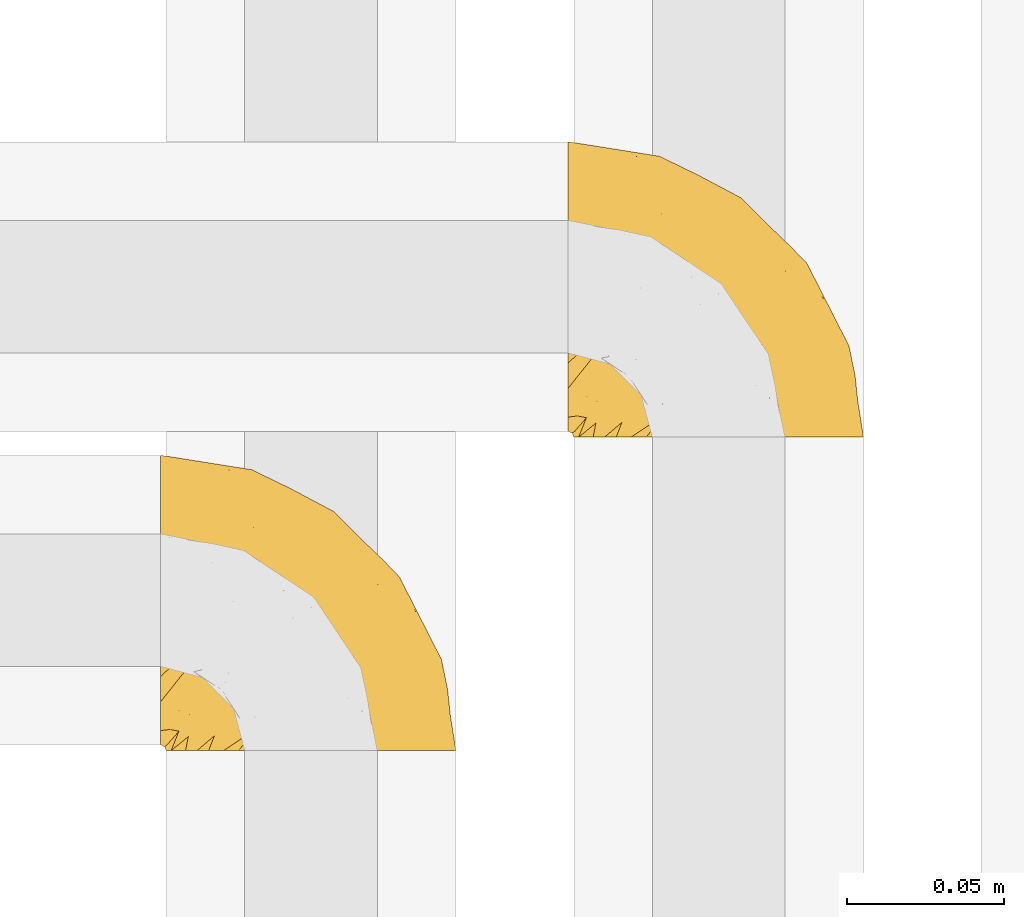
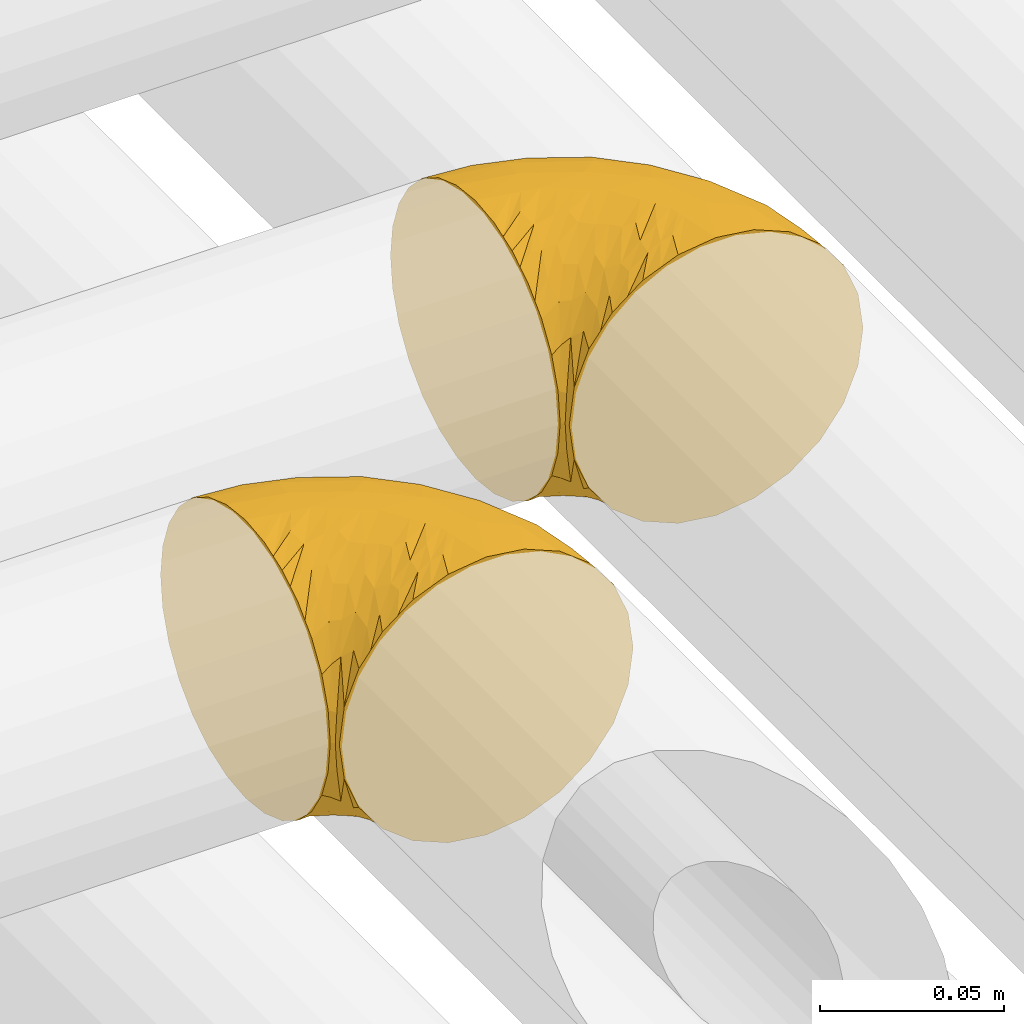
# One storey, part 254 of 827: 2 coverings.
"""IFC2X3 building model written with IfcOpenShell, lengths in millimetres."""

from ifc_helpers import new_model, entity, si_unit, converted_unit, derived_unit, direction, frame, origin, place, context, subcontext, project, spatial, faceted_brep, element, save


model = new_model("IFC2X3")

# Units and contexts
model_context = context("Model", 3, precision=0.01, world=origin(), true_north=direction((6.12303176911189e-17, 1.0)))
body_context = subcontext(model_context, "Body", "Model", "MODEL_VIEW")
ifc_project = project(units=[si_unit("LENGTHUNIT", "METRE", prefix="MILLI"), si_unit("AREAUNIT", "SQUARE_METRE"), si_unit("VOLUMEUNIT", "CUBIC_METRE"), converted_unit("PLANEANGLEUNIT", "DEGREE", entity("IfcRatioMeasure", 0.0174532925199433), si_unit("PLANEANGLEUNIT", "RADIAN"), dimensions=[0, 0, 0, 0, 0, 0, 0]), si_unit("MASSUNIT", "GRAM", prefix="KILO"), derived_unit("MASSDENSITYUNIT", [(si_unit("MASSUNIT", "GRAM", prefix="KILO"), 1), (si_unit("LENGTHUNIT", "METRE"), -3)]), derived_unit("MOMENTOFINERTIAUNIT", [(si_unit("LENGTHUNIT", "METRE"), 4)]), si_unit("TIMEUNIT", "SECOND"), si_unit("FREQUENCYUNIT", "HERTZ"), si_unit("THERMODYNAMICTEMPERATUREUNIT", "DEGREE_CELSIUS"), derived_unit("THERMALTRANSMITTANCEUNIT", [(si_unit("MASSUNIT", "GRAM", prefix="KILO"), 1), (si_unit("THERMODYNAMICTEMPERATUREUNIT", "KELVIN"), -1), (si_unit("TIMEUNIT", "SECOND"), -3)]), derived_unit("VOLUMETRICFLOWRATEUNIT", [(si_unit("LENGTHUNIT", "METRE"), 3), (si_unit("TIMEUNIT", "SECOND"), -1)]), derived_unit("MASSFLOWRATEUNIT", [(si_unit("MASSUNIT", "GRAM", prefix="KILO"), 1), (si_unit("TIMEUNIT", "SECOND"), -1)]), derived_unit("ROTATIONALFREQUENCYUNIT", [(si_unit("TIMEUNIT", "SECOND"), -1)]), si_unit("ELECTRICCURRENTUNIT", "AMPERE"), si_unit("ELECTRICVOLTAGEUNIT", "VOLT"), si_unit("POWERUNIT", "WATT"), si_unit("FORCEUNIT", "NEWTON", prefix="KILO"), si_unit("ILLUMINANCEUNIT", "LUX"), si_unit("LUMINOUSFLUXUNIT", "LUMEN"), si_unit("LUMINOUSINTENSITYUNIT", "CANDELA"), derived_unit("USERDEFINED", [(si_unit("MASSUNIT", "GRAM", prefix="KILO"), -1), (si_unit("LENGTHUNIT", "METRE"), -2), (si_unit("TIMEUNIT", "SECOND"), 3), (si_unit("LUMINOUSFLUXUNIT", "LUMEN"), 1)]), derived_unit("LINEARVELOCITYUNIT", [(si_unit("LENGTHUNIT", "METRE"), 1), (si_unit("TIMEUNIT", "SECOND"), -1)]), si_unit("PRESSUREUNIT", "PASCAL"), derived_unit("USERDEFINED", [(si_unit("LENGTHUNIT", "METRE"), -2), (si_unit("MASSUNIT", "GRAM", prefix="KILO"), 1), (si_unit("TIMEUNIT", "SECOND"), -2)]), derived_unit("LINEARFORCEUNIT", [(si_unit("MASSUNIT", "GRAM", prefix="KILO"), 1), (si_unit("LENGTHUNIT", "METRE"), 1), (si_unit("TIMEUNIT", "SECOND"), -2), (si_unit("LENGTHUNIT", "METRE"), -1)]), derived_unit("PLANARFORCEUNIT", [(si_unit("MASSUNIT", "GRAM", prefix="KILO"), 1), (si_unit("LENGTHUNIT", "METRE"), 1), (si_unit("TIMEUNIT", "SECOND"), -2), (si_unit("LENGTHUNIT", "METRE"), -2)])], contexts=[model_context])

# Site, building, storey
site_placement = place(None, origin())
site = spatial("IfcSite", under=ifc_project, at=site_placement, CompositionType="ELEMENT")
building_placement = place(site_placement, origin())
building = spatial("IfcBuilding", under=site, at=building_placement, CompositionType="ELEMENT")
storey_placement = place(building_placement, frame((0.0, 0.0, 28200.0)))
storey = spatial("IfcBuildingStorey", under=building, at=storey_placement, Name="08", CompositionType="ELEMENT", Elevation=28200.0)

# Coverings
covering_1_placement = place(storey_placement, frame((30866.93, 15691.61, 3152.2)))
element("IfcCovering", 1, at=covering_1_placement, inside=storey, Name=":ADSK_", ObjectType=":ADSK_", PredefinedType="INSULATION", context=body_context, shape_type="Brep", body=[
    faceted_brep([(1.6, 78.41, 83.91), (1.6, 85.72, 76.59), (1.6, 91.22, 67.83), (1.6, 94.64, 58.07), (1.6, 95.8, 47.8), (1.6, 94.64, 37.51), (1.6, 91.22, 27.74), (1.6, 85.71, 18.98), (1.6, 78.39, 11.67), (1.6, 69.63, 6.17), (1.6, 59.87, 2.75), (1.6, 49.6, 1.6), (1.6, 45.45, 2.06), (1.6, 42.38, 2.41), (1.6, 39.31, 2.75), (1.6, 34.43, 4.46), (1.6, 29.54, 6.17), (1.6, 25.16, 8.93), (1.6, 20.78, 11.68), (1.6, 17.13, 15.34), (1.6, 13.47, 19.0), (1.6, 7.97, 27.76), (1.6, 6.26, 32.64), (1.6, 4.55, 37.52), (1.6, 3.4, 47.8), (1.6, 4.55, 58.08), (1.6, 6.26, 62.96), (1.6, 7.97, 67.85), (1.6, 13.48, 76.61), (1.6, 17.14, 80.26), (1.6, 20.8, 83.92), (1.6, 25.18, 86.67), (1.6, 29.56, 89.42), (1.6, 34.44, 91.13), (1.6, 39.32, 92.84), (1.6, 42.39, 93.18), (1.6, 45.45, 93.53), (1.6, 49.6, 94.0), (1.6, 59.88, 92.84), (1.6, 69.65, 89.42), (3.4, 1.6, 47.8), (4.97, 1.6, 35.84), (9.58, 1.6, 24.7), (13.26, 1.6, 19.91), (16.93, 1.6, 15.13), (21.71, 1.6, 11.46), (26.5, 1.6, 7.78), (32.07, 1.6, 5.48), (37.64, 1.6, 3.17), (41.25, 1.6, 2.69), (43.34, 1.6, 2.42), (45.42, 1.6, 2.14), (49.6, 1.6, 1.6), (61.55, 1.6, 3.17), (72.7, 1.6, 7.78), (82.26, 1.6, 15.13), (89.61, 1.6, 24.7), (94.22, 1.6, 35.84), (95.8, 1.6, 47.8), (94.22, 1.6, 59.75), (89.61, 1.6, 70.9), (82.26, 1.6, 80.46), (72.7, 1.6, 87.81), (61.55, 1.6, 92.42), (49.6, 1.6, 94.0), (45.42, 1.6, 93.45), (41.25, 1.6, 92.9), (37.64, 1.6, 92.42), (32.07, 1.6, 90.11), (26.5, 1.6, 87.81), (21.71, 1.6, 84.13), (16.93, 1.6, 80.46), (13.26, 1.6, 75.68), (9.58, 1.6, 70.9), (4.97, 1.6, 59.75), (81.55, 36.81, 71.98), (90.4, 23.28, 63.6), (83.0, 45.8, 59.72), (91.18, 30.7, 47.8), (93.13, 21.2, 55.16), (94.0, 12.96, 47.8), (66.19, 66.19, 63.76), (70.92, 54.51, 72.22), (85.95, 17.98, 74.18), (49.74, 36.69, 92.52), (35.54, 35.54, 94.0), (38.14, 31.64, 94.0), (40.74, 27.75, 94.0), (43.34, 23.86, 94.0), (45.94, 19.96, 94.0), (77.59, 22.8, 82.14), (71.17, 42.67, 80.34), (65.81, 33.21, 87.52), (59.03, 59.45, 79.59), (45.85, 71.5, 78.25), (45.79, 62.66, 85.01), (41.42, 54.5, 90.25), (34.51, 47.57, 93.2), (56.04, 48.81, 87.23), (15.15, 74.98, 85.55), (56.51, 18.7, 93.0), (68.39, 15.75, 89.31), (23.33, 91.17, 61.31), (42.86, 85.28, 56.86), (39.42, 82.58, 68.34), (53.58, 75.78, 65.71), (59.17, 74.98, 56.99), (59.06, 67.27, 72.15), (22.63, 87.38, 70.34), (20.55, 82.04, 78.36), (12.96, 94.0, 47.8), (56.96, 77.8, 47.8), (67.38, 67.38, 47.8), (18.72, 56.2, 93.06), (5.33, 48.85, 94.0), (9.07, 48.11, 94.0), (11.79, 47.57, 94.0), (14.51, 47.03, 94.0), (17.24, 46.48, 94.0), (19.96, 45.94, 94.0), (21.03, 65.78, 89.88), (46.48, 17.24, 94.0), (47.03, 14.51, 94.0), (47.57, 11.79, 94.0), (48.11, 9.07, 94.0), (48.48, 7.2, 94.0), (48.85, 5.33, 94.0), (30.7, 91.18, 47.8), (23.86, 43.34, 94.0), (27.75, 40.74, 94.0), (31.64, 38.14, 94.0), (31.26, 72.73, 83.7), (77.8, 56.96, 47.8), (72.75, 62.23, 55.9), (43.83, 84.49, 47.8), (84.49, 43.83, 47.8), (14.58, 12.05, 81.75), (16.17, 18.95, 86.43), (10.82, 13.02, 79.8), (4.64, 8.34, 69.84), (7.71, 14.63, 79.5), (25.13, 11.09, 88.08), (32.66, 13.66, 91.6), (34.94, 20.08, 92.93), (36.76, 9.61, 92.43), (40.48, 9.48, 93.24), (39.25, 16.1, 93.36), (3.69, 3.42, 57.25), (13.99, 26.63, 89.41), (21.85, 33.72, 92.89), (17.93, 34.77, 92.66), (15.11, 6.75, 79.58), (21.14, 13.31, 86.51), (12.7, 21.11, 86.29), (7.21, 19.94, 83.91), (10.45, 6.04, 73.94), (32.27, 8.67, 90.94), (25.68, 26.11, 91.94), (22.18, 29.3, 91.98), (18.79, 6.32, 82.79), (10.12, 39.92, 93.16), (9.47, 27.05, 88.76), (11.29, 34.4, 91.89), (2.87, 2.87, 47.8), (31.16, 20.92, 92.22), (6.31, 27.43, 88.56), (25.62, 7.54, 87.72), (21.18, 18.45, 88.33), (28.81, 23.88, 92.18), (7.45, 7.77, 71.78), (21.17, 18.43, 7.27), (16.17, 18.93, 9.17), (25.69, 26.08, 3.66), (48.85, 5.33, 1.6), (47.03, 14.51, 1.6), (47.57, 11.79, 1.6), (48.11, 9.07, 1.6), (3.69, 3.42, 38.35), (7.44, 7.76, 23.84), (14.51, 47.03, 1.6), (11.79, 47.57, 1.6), (5.33, 48.85, 1.6), (9.07, 48.11, 1.6), (7.71, 14.62, 16.1), (9.47, 27.03, 6.84), (34.94, 20.08, 2.66), (31.16, 20.92, 3.37), (40.74, 27.75, 1.6), (38.14, 31.64, 1.6), (18.79, 6.33, 12.8), (36.76, 9.61, 3.16), (40.48, 9.48, 2.35), (4.63, 8.33, 25.77), (21.14, 13.3, 9.09), (15.11, 6.74, 16.02), (14.58, 12.04, 13.85), (43.34, 23.86, 1.6), (45.94, 19.96, 1.6), (39.25, 16.1, 2.23), (7.21, 19.93, 11.69), (12.69, 21.1, 9.31), (10.14, 39.92, 2.43), (21.81, 33.68, 2.71), (22.19, 29.28, 3.61), (14.0, 26.62, 6.18), (6.66, 27.87, 6.77), (17.92, 34.75, 2.93), (10.45, 6.04, 21.66), (31.64, 38.14, 1.6), (10.64, 12.79, 16.09), (11.31, 34.41, 3.7), (19.96, 45.94, 1.6), (23.86, 43.34, 1.6), (27.75, 40.74, 1.6), (32.66, 13.66, 3.99), (46.48, 17.24, 1.6), (32.27, 8.67, 4.65), (25.13, 11.09, 7.51), (35.54, 35.54, 1.6), (28.77, 23.83, 3.43), (23.36, 6.03, 9.46), (17.24, 46.48, 1.6), (47.58, 34.52, 2.4), (93.13, 21.2, 40.43), (77.44, 23.82, 13.57), (66.78, 41.32, 11.3), (71.68, 47.62, 18.65), (74.96, 52.66, 27.26), (81.55, 36.81, 23.61), (36.7, 49.75, 3.07), (56.9, 19.07, 2.69), (83.0, 45.8, 35.87), (90.4, 23.28, 31.99), (67.83, 21.35, 6.71), (85.95, 17.98, 21.41), (39.41, 82.57, 27.24), (23.33, 91.17, 34.26), (42.87, 85.27, 38.73), (53.92, 73.89, 26.97), (66.19, 66.19, 31.83), (64.12, 62.43, 23.4), (33.13, 63.53, 6.91), (23.1, 58.45, 3.4), (16.98, 67.16, 5.84), (72.75, 62.22, 39.69), (23.77, 81.54, 17.6), (18.41, 74.8, 10.38), (43.7, 75.83, 20.6), (54.53, 41.45, 5.36), (55.72, 76.72, 35.73), (17.73, 88.2, 24.84), (38.98, 71.6, 13.87), (50.28, 56.23, 9.06), (59.02, 59.44, 15.99)], [[[0, 1, 2, 3, 4, 5, 6, 7, 8, 9, 10, 11, 12, 13, 14, 15, 16, 17, 18, 19, 20, 21, 22, 23, 24, 25, 26, 27, 28, 29, 30, 31, 32, 33, 34, 35, 36, 37, 38, 39]], [[40, 41, 42, 43, 44, 45, 46, 47, 48, 49, 50, 51, 52, 53, 54, 55, 56, 57, 58, 59, 60, 61, 62, 63, 64, 65, 66, 67, 68, 69, 70, 71, 72, 73, 74]], [[75, 76, 77]], [[78, 79, 80]], [[77, 81, 82]], [[76, 75, 83]], [[84, 85, 86, 87, 88, 89]], [[90, 91, 92]], [[76, 60, 59]], [[93, 94, 95]], [[90, 62, 61]], [[83, 61, 60]], [[96, 97, 84]], [[98, 93, 95]], [[0, 39, 99]], [[100, 84, 89]], [[62, 101, 63]], [[2, 102, 3]], [[92, 84, 100]], [[103, 102, 104]], [[103, 105, 106]], [[93, 107, 94]], [[1, 108, 2]], [[92, 101, 90]], [[108, 1, 109]], [[102, 110, 3]], [[93, 82, 107]], [[102, 108, 104]], [[111, 106, 112]], [[109, 0, 99]], [[113, 37, 114, 115, 116, 117, 118, 119]], [[120, 38, 113]], [[100, 89, 121, 122, 123, 124, 125, 126, 64]], [[127, 102, 103]], [[97, 119, 128, 129, 130, 85]], [[99, 120, 131]], [[132, 133, 77]], [[59, 80, 79]], [[1, 0, 109]], [[98, 84, 92]], [[94, 109, 131]], [[120, 39, 38]], [[93, 91, 82]], [[104, 94, 105]], [[97, 113, 119]], [[95, 120, 96]], [[83, 90, 61]], [[91, 93, 98]], [[64, 63, 100]], [[100, 63, 101]], [[77, 76, 79]], [[133, 106, 81]], [[84, 97, 85]], [[113, 96, 120]], [[113, 97, 96]], [[37, 113, 38]], [[110, 102, 127]], [[110, 4, 3]], [[103, 111, 134, 127]], [[90, 75, 91]], [[82, 81, 107]], [[91, 75, 82]], [[77, 82, 75]], [[76, 83, 60]], [[90, 83, 75]], [[105, 107, 81]], [[94, 131, 95]], [[105, 94, 107]], [[109, 94, 104]], [[120, 95, 131]], [[98, 95, 96]], [[84, 98, 96]], [[98, 92, 91]], [[106, 105, 81]], [[103, 104, 105]], [[133, 132, 112]], [[103, 106, 111]], [[77, 78, 135, 132]], [[106, 133, 112]], [[77, 133, 81]], [[120, 99, 39]], [[109, 99, 131]], [[59, 58, 80]], [[59, 79, 76]], [[90, 101, 62]], [[100, 101, 92]], [[2, 108, 102]], [[109, 104, 108]], [[78, 77, 79]], [[136, 137, 138]], [[27, 139, 140]], [[141, 142, 143]], [[144, 145, 121]], [[146, 89, 88]], [[147, 139, 25]], [[148, 149, 150]], [[136, 151, 152]], [[147, 40, 74]], [[24, 147, 25]], [[140, 153, 154]], [[33, 116, 34]], [[73, 151, 155]], [[114, 37, 36, 35, 34, 116, 115]], [[146, 156, 144]], [[157, 85, 130]], [[158, 149, 148]], [[151, 159, 152]], [[117, 33, 160]], [[29, 154, 161]], [[155, 74, 73]], [[162, 128, 119]], [[65, 64, 126, 125, 124, 123, 122, 67, 66]], [[163, 147, 24]], [[27, 140, 28]], [[149, 129, 150]], [[139, 27, 26, 25]], [[68, 144, 69]], [[129, 128, 150]], [[164, 87, 86]], [[130, 129, 149]], [[122, 145, 67]], [[154, 153, 148]], [[162, 119, 160]], [[165, 30, 161]], [[150, 161, 148]], [[128, 162, 150]], [[30, 165, 31]], [[145, 144, 68]], [[89, 146, 144]], [[87, 164, 143]], [[166, 156, 142]], [[88, 87, 143]], [[162, 161, 150]], [[161, 30, 29]], [[154, 29, 28]], [[140, 154, 28]], [[161, 154, 148]], [[140, 137, 153]], [[158, 148, 153]], [[157, 130, 158]], [[153, 137, 158]], [[158, 137, 157]], [[167, 137, 136]], [[168, 85, 157]], [[152, 168, 167]], [[167, 168, 157]], [[164, 152, 141]], [[151, 73, 72]], [[159, 72, 71]], [[88, 142, 146]], [[144, 156, 69]], [[146, 142, 156]], [[70, 166, 71]], [[142, 141, 166]], [[70, 69, 156]], [[141, 159, 71]], [[167, 136, 152]], [[138, 137, 140]], [[155, 136, 169]], [[136, 155, 151]], [[74, 155, 169]], [[152, 159, 141]], [[151, 72, 159]], [[168, 152, 164]], [[137, 167, 157]], [[164, 86, 168]], [[85, 168, 86]], [[116, 33, 117]], [[130, 149, 158]], [[67, 145, 68]], [[121, 89, 144]], [[145, 122, 121]], [[40, 147, 163]], [[169, 147, 74]], [[160, 33, 32]], [[162, 160, 32]], [[160, 119, 118, 117]], [[139, 147, 169]], [[139, 169, 138]], [[162, 32, 31]], [[141, 143, 164]], [[88, 143, 142]], [[71, 166, 141]], [[156, 166, 70]], [[139, 138, 140]], [[169, 136, 138]], [[161, 162, 165]], [[162, 31, 165]], [[170, 171, 172]], [[173, 52, 51, 50, 49, 48, 174, 175, 176]], [[177, 178, 41]], [[179, 15, 180]], [[12, 11, 181, 182, 180, 14, 13]], [[183, 21, 20]], [[19, 18, 184]], [[185, 186, 187]], [[186, 188, 187]], [[43, 189, 44]], [[190, 191, 47]], [[23, 22, 21, 192]], [[193, 194, 195]], [[40, 163, 177]], [[196, 197, 198]], [[24, 23, 177]], [[199, 200, 183]], [[201, 15, 179]], [[178, 177, 192]], [[47, 46, 190]], [[202, 203, 204]], [[203, 172, 171]], [[205, 206, 184]], [[207, 41, 178]], [[16, 15, 201]], [[14, 180, 15]], [[204, 203, 200]], [[208, 203, 202]], [[163, 24, 177]], [[48, 47, 191]], [[198, 197, 190]], [[199, 184, 204]], [[171, 195, 209]], [[210, 211, 212]], [[206, 212, 213]], [[205, 17, 210]], [[184, 206, 204]], [[210, 212, 206]], [[185, 196, 214]], [[190, 215, 191]], [[216, 45, 214]], [[186, 217, 193]], [[190, 216, 198]], [[19, 184, 199]], [[196, 185, 187]], [[19, 199, 20]], [[200, 199, 204]], [[183, 20, 199]], [[206, 202, 204]], [[171, 183, 200]], [[203, 208, 172]], [[172, 208, 218]], [[171, 200, 203]], [[218, 188, 219]], [[195, 170, 193]], [[217, 186, 185]], [[193, 219, 186]], [[193, 170, 219]], [[207, 194, 42]], [[217, 220, 189]], [[216, 190, 46]], [[214, 196, 198]], [[44, 220, 45]], [[214, 198, 216]], [[216, 46, 45]], [[214, 45, 220]], [[42, 194, 43]], [[189, 193, 217]], [[207, 195, 194]], [[209, 195, 178]], [[41, 207, 42]], [[195, 207, 178]], [[43, 194, 189]], [[193, 189, 194]], [[171, 170, 195]], [[170, 172, 219]], [[218, 219, 172]], [[188, 186, 219]], [[206, 213, 202]], [[208, 202, 213]], [[201, 210, 16]], [[215, 190, 197]], [[215, 174, 191]], [[174, 48, 191]], [[201, 179, 221, 211]], [[210, 201, 211]], [[23, 192, 177]], [[40, 177, 41]], [[192, 183, 209]], [[21, 183, 192]], [[205, 18, 17]], [[17, 16, 210]], [[217, 185, 214]], [[189, 220, 44]], [[214, 220, 217]], [[192, 209, 178]], [[171, 209, 183]], [[206, 205, 210]], [[18, 205, 184]], [[222, 197, 196, 187, 188, 218]], [[57, 223, 80]], [[224, 225, 226]], [[226, 227, 228]], [[229, 218, 208, 213, 212, 211]], [[230, 52, 173, 176, 175, 174, 215, 197]], [[231, 232, 228]], [[231, 78, 223]], [[223, 57, 232]], [[224, 233, 225]], [[233, 54, 53]], [[234, 232, 56]], [[56, 55, 234]], [[234, 224, 228]], [[235, 236, 237]], [[224, 55, 54]], [[238, 239, 240]], [[52, 230, 53]], [[241, 242, 243]], [[227, 244, 231]], [[11, 10, 242]], [[236, 6, 5]], [[7, 245, 8]], [[8, 246, 9]], [[238, 247, 235]], [[222, 229, 248]], [[242, 211, 221, 179, 180, 182, 181, 11]], [[233, 53, 230]], [[111, 112, 249]], [[250, 6, 236]], [[246, 251, 241]], [[6, 250, 7]], [[127, 236, 110]], [[248, 229, 252]], [[246, 8, 245]], [[235, 245, 250]], [[236, 5, 110]], [[235, 249, 238]], [[237, 236, 127]], [[243, 9, 246]], [[252, 229, 241]], [[56, 232, 57]], [[222, 230, 197]], [[225, 248, 252]], [[248, 233, 230]], [[54, 233, 224]], [[231, 228, 227]], [[244, 132, 231]], [[248, 225, 233]], [[226, 225, 253]], [[235, 250, 236]], [[245, 7, 250]], [[251, 246, 245]], [[243, 246, 241]], [[247, 245, 235]], [[252, 251, 253]], [[229, 222, 218]], [[230, 222, 248]], [[5, 4, 110]], [[237, 127, 134, 111]], [[238, 249, 239]], [[224, 234, 55]], [[232, 234, 228]], [[242, 241, 229]], [[10, 9, 243]], [[211, 242, 229]], [[10, 243, 242]], [[80, 223, 78]], [[80, 58, 57]], [[231, 223, 232]], [[227, 240, 239]], [[224, 226, 228]], [[240, 226, 253]], [[227, 239, 244]], [[226, 240, 227]], [[251, 247, 253]], [[240, 253, 247]], [[249, 235, 237]], [[237, 111, 249]], [[112, 132, 244]], [[112, 244, 249]], [[78, 231, 132, 135]], [[249, 244, 239]], [[247, 238, 240]], [[245, 247, 251]], [[251, 252, 241]], [[225, 252, 253]]]),
])
covering_2_placement = place(storey_placement, frame((30996.93, 15791.61, 3152.2)))
element("IfcCovering", 2, at=covering_2_placement, inside=storey, Name=":ADSK_", ObjectType=":ADSK_", PredefinedType="INSULATION", context=body_context, shape_type="Brep", body=[
    faceted_brep([(1.6, 78.41, 83.91), (1.6, 85.72, 76.59), (1.6, 91.22, 67.83), (1.6, 94.64, 58.07), (1.6, 95.8, 47.8), (1.6, 94.64, 37.51), (1.6, 91.22, 27.74), (1.6, 85.71, 18.98), (1.6, 78.39, 11.67), (1.6, 69.63, 6.17), (1.6, 59.87, 2.75), (1.6, 49.6, 1.6), (1.6, 45.45, 2.06), (1.6, 42.38, 2.41), (1.6, 39.31, 2.75), (1.6, 34.43, 4.46), (1.6, 29.54, 6.17), (1.6, 25.16, 8.93), (1.6, 20.78, 11.68), (1.6, 17.13, 15.34), (1.6, 13.47, 19.0), (1.6, 7.97, 27.76), (1.6, 6.26, 32.64), (1.6, 4.55, 37.52), (1.6, 3.4, 47.8), (1.6, 4.55, 58.08), (1.6, 6.26, 62.96), (1.6, 7.97, 67.85), (1.6, 13.48, 76.61), (1.6, 17.14, 80.26), (1.6, 20.8, 83.92), (1.6, 25.18, 86.67), (1.6, 29.56, 89.42), (1.6, 34.44, 91.13), (1.6, 39.32, 92.84), (1.6, 42.39, 93.18), (1.6, 45.45, 93.53), (1.6, 49.6, 94.0), (1.6, 59.88, 92.84), (1.6, 69.65, 89.42), (3.4, 1.6, 47.8), (4.97, 1.6, 35.84), (9.58, 1.6, 24.7), (13.26, 1.6, 19.91), (16.93, 1.6, 15.13), (21.71, 1.6, 11.46), (26.5, 1.6, 7.78), (32.07, 1.6, 5.48), (37.64, 1.6, 3.17), (41.25, 1.6, 2.69), (43.34, 1.6, 2.42), (45.42, 1.6, 2.14), (49.6, 1.6, 1.6), (61.55, 1.6, 3.17), (72.7, 1.6, 7.78), (82.26, 1.6, 15.13), (89.61, 1.6, 24.7), (94.22, 1.6, 35.84), (95.8, 1.6, 47.8), (94.22, 1.6, 59.75), (89.61, 1.6, 70.9), (82.26, 1.6, 80.46), (72.7, 1.6, 87.81), (61.55, 1.6, 92.42), (49.6, 1.6, 94.0), (45.42, 1.6, 93.45), (41.25, 1.6, 92.9), (37.64, 1.6, 92.42), (32.07, 1.6, 90.11), (26.5, 1.6, 87.81), (21.71, 1.6, 84.13), (16.93, 1.6, 80.46), (13.26, 1.6, 75.68), (9.58, 1.6, 70.9), (4.97, 1.6, 59.75), (81.55, 36.81, 71.98), (90.4, 23.28, 63.6), (83.0, 45.8, 59.72), (91.18, 30.7, 47.8), (93.13, 21.2, 55.16), (94.0, 12.96, 47.8), (66.19, 66.19, 63.76), (70.92, 54.51, 72.22), (85.95, 17.98, 74.18), (49.74, 36.69, 92.52), (35.54, 35.54, 94.0), (38.14, 31.64, 94.0), (40.74, 27.75, 94.0), (43.34, 23.86, 94.0), (45.94, 19.96, 94.0), (77.59, 22.8, 82.14), (71.17, 42.67, 80.34), (65.81, 33.21, 87.52), (59.03, 59.45, 79.59), (45.85, 71.5, 78.25), (45.79, 62.66, 85.01), (41.42, 54.5, 90.25), (34.51, 47.57, 93.2), (56.04, 48.81, 87.23), (15.15, 74.98, 85.55), (56.51, 18.7, 93.0), (68.39, 15.75, 89.31), (23.33, 91.17, 61.31), (42.86, 85.28, 56.86), (39.42, 82.58, 68.34), (53.58, 75.78, 65.71), (59.17, 74.98, 56.99), (59.06, 67.27, 72.15), (22.63, 87.38, 70.34), (20.55, 82.04, 78.36), (12.96, 94.0, 47.8), (56.96, 77.8, 47.8), (67.38, 67.38, 47.8), (18.72, 56.2, 93.06), (5.33, 48.85, 94.0), (9.07, 48.11, 94.0), (11.79, 47.57, 94.0), (14.51, 47.03, 94.0), (17.24, 46.48, 94.0), (19.96, 45.94, 94.0), (21.03, 65.78, 89.88), (46.48, 17.24, 94.0), (47.03, 14.51, 94.0), (47.57, 11.79, 94.0), (48.11, 9.07, 94.0), (48.48, 7.2, 94.0), (48.85, 5.33, 94.0), (30.7, 91.18, 47.8), (23.86, 43.34, 94.0), (27.75, 40.74, 94.0), (31.64, 38.14, 94.0), (31.26, 72.73, 83.7), (77.8, 56.96, 47.8), (72.75, 62.23, 55.9), (43.83, 84.49, 47.8), (84.49, 43.83, 47.8), (14.58, 12.05, 81.75), (16.17, 18.95, 86.43), (10.82, 13.02, 79.8), (4.64, 8.34, 69.84), (7.71, 14.63, 79.5), (25.13, 11.09, 88.08), (32.66, 13.66, 91.6), (34.94, 20.08, 92.93), (36.76, 9.61, 92.43), (40.48, 9.48, 93.24), (39.25, 16.1, 93.36), (3.69, 3.42, 57.25), (13.99, 26.63, 89.41), (21.85, 33.72, 92.89), (17.93, 34.77, 92.66), (15.11, 6.75, 79.58), (21.14, 13.31, 86.51), (7.21, 19.94, 83.91), (9.47, 27.05, 88.76), (10.45, 6.04, 73.94), (32.27, 8.67, 90.94), (25.68, 26.11, 91.94), (22.18, 29.3, 91.98), (18.79, 6.32, 82.79), (10.12, 39.92, 93.16), (11.29, 34.4, 91.89), (2.87, 2.87, 47.8), (31.16, 20.92, 92.22), (12.7, 21.11, 86.29), (6.31, 27.43, 88.56), (25.62, 7.54, 87.72), (21.18, 18.45, 88.33), (28.81, 23.88, 92.18), (7.45, 7.77, 71.78), (21.14, 13.3, 9.09), (25.13, 11.09, 7.51), (18.79, 6.33, 12.8), (48.11, 9.07, 1.6), (48.85, 5.33, 1.6), (47.03, 14.51, 1.6), (47.57, 11.79, 1.6), (3.69, 3.42, 38.35), (7.44, 7.76, 23.84), (14.51, 47.03, 1.6), (11.79, 47.57, 1.6), (5.33, 48.85, 1.6), (9.07, 48.11, 1.6), (7.71, 14.62, 16.1), (9.47, 27.03, 6.84), (34.94, 20.08, 2.66), (31.16, 20.92, 3.37), (40.74, 27.75, 1.6), (38.14, 31.64, 1.6), (36.76, 9.61, 3.16), (40.48, 9.48, 2.35), (4.63, 8.33, 25.77), (15.11, 6.74, 16.02), (14.58, 12.04, 13.85), (43.34, 23.86, 1.6), (45.94, 19.96, 1.6), (39.25, 16.1, 2.23), (7.21, 19.93, 11.69), (12.69, 21.1, 9.31), (10.14, 39.92, 2.43), (21.81, 33.68, 2.71), (22.19, 29.28, 3.61), (14.0, 26.62, 6.18), (25.69, 26.08, 3.66), (16.17, 18.93, 9.17), (6.66, 27.87, 6.77), (17.92, 34.75, 2.93), (10.45, 6.04, 21.66), (31.64, 38.14, 1.6), (10.64, 12.79, 16.09), (11.31, 34.41, 3.7), (19.96, 45.94, 1.6), (23.86, 43.34, 1.6), (27.75, 40.74, 1.6), (32.66, 13.66, 3.99), (46.48, 17.24, 1.6), (32.27, 8.67, 4.65), (35.54, 35.54, 1.6), (28.77, 23.83, 3.43), (21.17, 18.43, 7.27), (23.36, 6.03, 9.46), (17.24, 46.48, 1.6), (47.58, 34.52, 2.4), (93.13, 21.2, 40.43), (77.44, 23.82, 13.57), (66.78, 41.32, 11.3), (71.68, 47.62, 18.65), (74.96, 52.66, 27.26), (81.55, 36.81, 23.61), (36.7, 49.75, 3.07), (56.9, 19.07, 2.69), (83.0, 45.8, 35.87), (90.4, 23.28, 31.99), (67.83, 21.35, 6.71), (85.95, 17.98, 21.41), (39.41, 82.57, 27.24), (23.33, 91.17, 34.26), (42.87, 85.27, 38.73), (53.92, 73.89, 26.97), (66.19, 66.19, 31.83), (64.12, 62.43, 23.4), (33.13, 63.53, 6.91), (23.1, 58.45, 3.4), (16.98, 67.16, 5.84), (55.72, 76.72, 35.73), (72.75, 62.22, 39.69), (23.77, 81.54, 17.6), (18.41, 74.8, 10.38), (43.7, 75.83, 20.6), (54.53, 41.45, 5.36), (17.73, 88.2, 24.84), (38.98, 71.6, 13.87), (50.28, 56.23, 9.06), (59.02, 59.44, 15.99)], [[[0, 1, 2, 3, 4, 5, 6, 7, 8, 9, 10, 11, 12, 13, 14, 15, 16, 17, 18, 19, 20, 21, 22, 23, 24, 25, 26, 27, 28, 29, 30, 31, 32, 33, 34, 35, 36, 37, 38, 39]], [[40, 41, 42, 43, 44, 45, 46, 47, 48, 49, 50, 51, 52, 53, 54, 55, 56, 57, 58, 59, 60, 61, 62, 63, 64, 65, 66, 67, 68, 69, 70, 71, 72, 73, 74]], [[75, 76, 77]], [[78, 79, 80]], [[77, 81, 82]], [[76, 75, 83]], [[84, 85, 86, 87, 88, 89]], [[90, 91, 92]], [[76, 60, 59]], [[93, 94, 95]], [[90, 62, 61]], [[83, 61, 60]], [[96, 97, 84]], [[98, 93, 95]], [[0, 39, 99]], [[100, 84, 89]], [[62, 101, 63]], [[2, 102, 3]], [[92, 84, 100]], [[103, 102, 104]], [[103, 105, 106]], [[93, 107, 94]], [[1, 108, 2]], [[92, 101, 90]], [[108, 1, 109]], [[102, 110, 3]], [[93, 82, 107]], [[102, 108, 104]], [[111, 106, 112]], [[109, 0, 99]], [[113, 37, 114, 115, 116, 117, 118, 119]], [[120, 38, 113]], [[100, 89, 121, 122, 123, 124, 125, 126, 64]], [[127, 102, 103]], [[97, 119, 128, 129, 130, 85]], [[99, 120, 131]], [[132, 133, 77]], [[59, 80, 79]], [[1, 0, 109]], [[98, 84, 92]], [[94, 109, 131]], [[120, 39, 38]], [[93, 91, 82]], [[104, 94, 105]], [[97, 113, 119]], [[95, 120, 96]], [[83, 90, 61]], [[91, 93, 98]], [[64, 63, 100]], [[100, 63, 101]], [[77, 76, 79]], [[133, 106, 81]], [[84, 97, 85]], [[113, 96, 120]], [[113, 97, 96]], [[37, 113, 38]], [[110, 102, 127]], [[110, 4, 3]], [[103, 111, 134, 127]], [[90, 75, 91]], [[82, 81, 107]], [[91, 75, 82]], [[77, 82, 75]], [[76, 83, 60]], [[90, 83, 75]], [[105, 107, 81]], [[94, 131, 95]], [[105, 94, 107]], [[109, 94, 104]], [[120, 95, 131]], [[98, 95, 96]], [[84, 98, 96]], [[98, 92, 91]], [[106, 105, 81]], [[103, 104, 105]], [[112, 106, 133]], [[103, 106, 111]], [[112, 133, 132]], [[81, 77, 133]], [[77, 78, 135, 132]], [[120, 99, 39]], [[109, 99, 131]], [[59, 58, 80]], [[59, 79, 76]], [[90, 101, 62]], [[100, 101, 92]], [[2, 108, 102]], [[109, 104, 108]], [[78, 77, 79]], [[136, 137, 138]], [[27, 139, 140]], [[141, 142, 143]], [[144, 145, 121]], [[146, 89, 88]], [[147, 139, 25]], [[148, 149, 150]], [[136, 151, 152]], [[147, 40, 74]], [[24, 147, 25]], [[153, 148, 154]], [[33, 116, 34]], [[73, 151, 155]], [[114, 37, 36, 35, 34, 116, 115]], [[146, 156, 144]], [[157, 85, 130]], [[158, 149, 148]], [[151, 159, 152]], [[117, 33, 160]], [[29, 153, 154]], [[155, 74, 73]], [[161, 128, 119]], [[66, 65, 64, 126, 125, 124, 123, 122, 67]], [[162, 147, 24]], [[27, 140, 28]], [[149, 129, 150]], [[139, 27, 26, 25]], [[68, 144, 69]], [[129, 128, 150]], [[163, 87, 86]], [[130, 129, 149]], [[122, 145, 67]], [[153, 164, 148]], [[161, 119, 160]], [[165, 30, 154]], [[150, 154, 148]], [[128, 161, 150]], [[30, 165, 31]], [[145, 144, 68]], [[89, 146, 144]], [[87, 163, 143]], [[166, 156, 142]], [[88, 87, 143]], [[161, 154, 150]], [[154, 30, 29]], [[29, 28, 153]], [[28, 140, 153]], [[164, 153, 140]], [[140, 137, 164]], [[158, 148, 164]], [[157, 130, 158]], [[164, 137, 158]], [[158, 137, 157]], [[167, 137, 136]], [[168, 85, 157]], [[152, 168, 167]], [[167, 168, 157]], [[163, 152, 141]], [[151, 73, 72]], [[159, 72, 71]], [[88, 142, 146]], [[144, 156, 69]], [[146, 142, 156]], [[70, 166, 71]], [[142, 141, 166]], [[70, 69, 156]], [[141, 159, 71]], [[167, 136, 152]], [[138, 137, 140]], [[155, 136, 169]], [[136, 155, 151]], [[74, 155, 169]], [[152, 159, 141]], [[151, 72, 159]], [[168, 152, 163]], [[137, 167, 157]], [[163, 86, 168]], [[85, 168, 86]], [[116, 33, 117]], [[130, 149, 158]], [[67, 145, 68]], [[121, 89, 144]], [[145, 122, 121]], [[40, 147, 162]], [[169, 147, 74]], [[160, 33, 32]], [[161, 160, 32]], [[160, 119, 118, 117]], [[139, 147, 169]], [[139, 169, 138]], [[161, 32, 31]], [[141, 143, 163]], [[88, 143, 142]], [[71, 166, 141]], [[156, 166, 70]], [[139, 138, 140]], [[169, 136, 138]], [[154, 161, 165]], [[161, 31, 165]], [[170, 171, 172]], [[173, 174, 52, 51, 50, 49, 48, 175, 176]], [[177, 178, 41]], [[179, 15, 180]], [[12, 11, 181, 182, 180, 14, 13]], [[183, 21, 20]], [[19, 18, 184]], [[185, 186, 187]], [[186, 188, 187]], [[43, 172, 44]], [[189, 190, 47]], [[23, 22, 21, 191]], [[170, 192, 193]], [[40, 162, 177]], [[194, 195, 196]], [[24, 23, 177]], [[197, 198, 183]], [[199, 15, 179]], [[47, 46, 189]], [[200, 201, 202]], [[201, 203, 204]], [[205, 206, 184]], [[207, 41, 178]], [[16, 15, 199]], [[14, 180, 15]], [[202, 201, 198]], [[208, 201, 200]], [[162, 24, 177]], [[48, 47, 190]], [[196, 195, 189]], [[197, 184, 202]], [[204, 193, 209]], [[210, 211, 212]], [[206, 212, 213]], [[205, 17, 210]], [[184, 206, 202]], [[210, 212, 206]], [[185, 194, 214]], [[189, 215, 190]], [[216, 45, 214]], [[186, 171, 170]], [[189, 216, 196]], [[197, 20, 19]], [[194, 185, 187]], [[197, 183, 20]], [[184, 197, 19]], [[197, 202, 198]], [[206, 200, 202]], [[204, 183, 198]], [[201, 208, 203]], [[203, 208, 217]], [[204, 198, 201]], [[217, 188, 218]], [[193, 219, 170]], [[171, 186, 185]], [[170, 218, 186]], [[170, 219, 218]], [[42, 207, 192]], [[171, 220, 172]], [[216, 189, 46]], [[214, 194, 196]], [[44, 220, 45]], [[214, 196, 216]], [[216, 46, 45]], [[214, 45, 220]], [[192, 43, 42]], [[204, 203, 219]], [[207, 193, 192]], [[209, 193, 178]], [[41, 207, 42]], [[193, 207, 178]], [[43, 192, 172]], [[170, 172, 192]], [[204, 219, 193]], [[219, 203, 218]], [[217, 218, 203]], [[188, 186, 218]], [[206, 213, 200]], [[208, 200, 213]], [[199, 210, 16]], [[215, 189, 195]], [[215, 175, 190]], [[175, 48, 190]], [[199, 179, 221, 211]], [[210, 199, 211]], [[23, 191, 177]], [[40, 177, 41]], [[183, 209, 191]], [[183, 191, 21]], [[191, 178, 177]], [[205, 18, 17]], [[17, 16, 210]], [[171, 185, 214]], [[172, 220, 44]], [[214, 220, 171]], [[191, 209, 178]], [[204, 209, 183]], [[206, 205, 210]], [[18, 205, 184]], [[222, 195, 194, 187, 188, 217]], [[57, 223, 80]], [[224, 225, 226]], [[226, 227, 228]], [[229, 217, 208, 213, 212, 211]], [[230, 52, 174, 173, 176, 175, 215, 195]], [[231, 232, 228]], [[231, 78, 223]], [[223, 57, 232]], [[224, 233, 225]], [[233, 54, 53]], [[234, 232, 56]], [[56, 55, 234]], [[234, 224, 228]], [[235, 236, 237]], [[224, 55, 54]], [[238, 239, 240]], [[52, 230, 53]], [[241, 242, 243]], [[239, 244, 245]], [[11, 10, 242]], [[236, 6, 5]], [[7, 246, 8]], [[8, 247, 9]], [[238, 248, 235]], [[222, 229, 249]], [[242, 211, 221, 179, 180, 182, 181, 11]], [[233, 53, 230]], [[111, 112, 244]], [[250, 6, 236]], [[247, 251, 241]], [[6, 250, 7]], [[127, 236, 110]], [[249, 229, 252]], [[247, 8, 246]], [[235, 246, 250]], [[236, 5, 110]], [[235, 244, 238]], [[237, 236, 127]], [[243, 9, 247]], [[252, 229, 241]], [[56, 232, 57]], [[222, 230, 195]], [[225, 249, 252]], [[249, 233, 230]], [[54, 233, 224]], [[231, 228, 227]], [[245, 132, 231]], [[249, 225, 233]], [[226, 225, 253]], [[235, 250, 236]], [[246, 7, 250]], [[251, 247, 246]], [[243, 247, 241]], [[248, 246, 235]], [[252, 251, 253]], [[229, 222, 217]], [[230, 222, 249]], [[5, 4, 110]], [[237, 127, 134, 111]], [[238, 244, 239]], [[224, 234, 55]], [[232, 234, 228]], [[242, 241, 229]], [[10, 9, 243]], [[211, 242, 229]], [[10, 243, 242]], [[80, 223, 78]], [[80, 58, 57]], [[231, 223, 232]], [[227, 240, 239]], [[224, 226, 228]], [[240, 226, 253]], [[227, 239, 245]], [[226, 240, 227]], [[251, 248, 253]], [[240, 253, 248]], [[244, 235, 237]], [[237, 111, 244]], [[132, 245, 112]], [[112, 245, 244]], [[135, 78, 231, 132]], [[227, 245, 231]], [[248, 238, 240]], [[246, 248, 251]], [[251, 252, 241]], [[225, 252, 253]]]),
])

save(model, "model.ifc")
